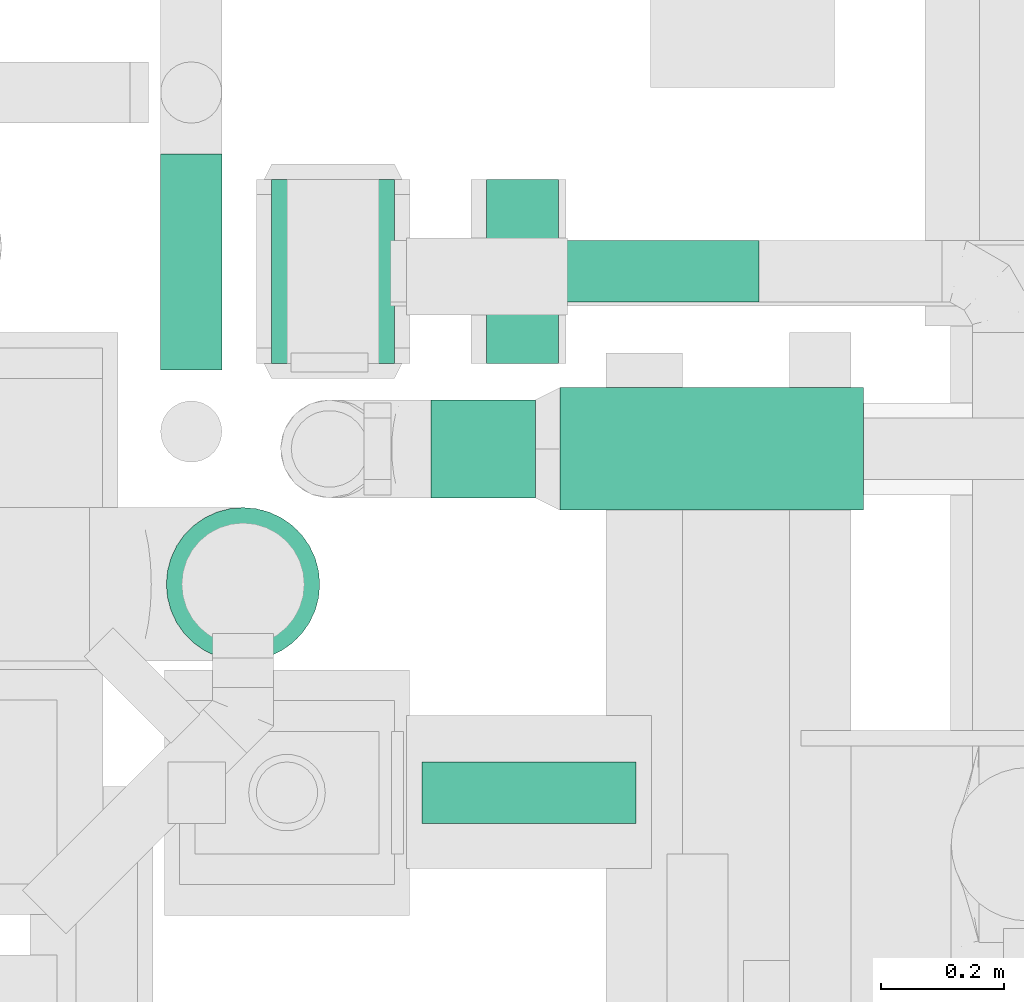
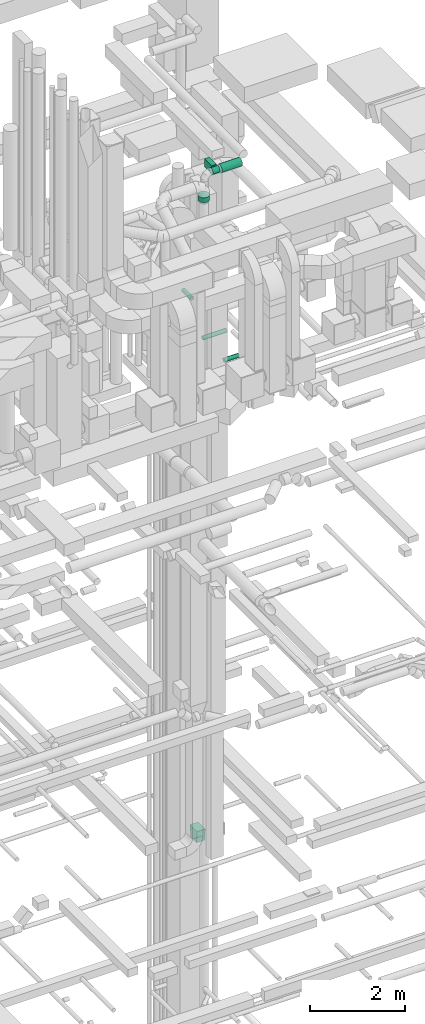
# One storey, part 236 of 337: 7 flow segments, 1 flow fitting.
"""IFC2X3 building model written with IfcOpenShell, lengths in millimetres."""

from ifc_helpers import new_model, entity, si_unit, converted_unit, derived_unit, direction, frame, origin, origin_2d_with_axis, place, context, subcontext, project, spatial, polyline, rectangle, circle, outline, extrude, source, transform, mapped, material, type_object, type_shapes, element, save


model = new_model("IFC2X3")

# Units and contexts
model_context = context("Model", 3, precision=0.01, world=origin(), true_north=direction((6.12303176911189e-17, 1.0)))
body_context = subcontext(model_context, "Body", "Model", "MODEL_VIEW")
ifc_project = project(units=[si_unit("LENGTHUNIT", "METRE", prefix="MILLI"), si_unit("AREAUNIT", "SQUARE_METRE"), si_unit("VOLUMEUNIT", "CUBIC_METRE"), converted_unit("PLANEANGLEUNIT", "DEGREE", entity("IfcRatioMeasure", 0.0174532925199433), si_unit("PLANEANGLEUNIT", "RADIAN"), dimensions=[0, 0, 0, 0, 0, 0, 0]), si_unit("MASSUNIT", "GRAM", prefix="KILO"), derived_unit("MASSDENSITYUNIT", [(si_unit("MASSUNIT", "GRAM", prefix="KILO"), 1), (si_unit("LENGTHUNIT", "METRE"), -3)]), derived_unit("MOMENTOFINERTIAUNIT", [(si_unit("LENGTHUNIT", "METRE"), 4)]), si_unit("TIMEUNIT", "SECOND"), si_unit("FREQUENCYUNIT", "HERTZ"), si_unit("THERMODYNAMICTEMPERATUREUNIT", "DEGREE_CELSIUS"), derived_unit("THERMALTRANSMITTANCEUNIT", [(si_unit("MASSUNIT", "GRAM", prefix="KILO"), 1), (si_unit("THERMODYNAMICTEMPERATUREUNIT", "KELVIN"), -1), (si_unit("TIMEUNIT", "SECOND"), -3)]), derived_unit("VOLUMETRICFLOWRATEUNIT", [(si_unit("LENGTHUNIT", "METRE"), 3), (si_unit("TIMEUNIT", "SECOND"), -1)]), derived_unit("MASSFLOWRATEUNIT", [(si_unit("MASSUNIT", "GRAM", prefix="KILO"), 1), (si_unit("TIMEUNIT", "SECOND"), -1)]), derived_unit("ROTATIONALFREQUENCYUNIT", [(si_unit("TIMEUNIT", "SECOND"), -1)]), si_unit("ELECTRICCURRENTUNIT", "AMPERE"), si_unit("ELECTRICVOLTAGEUNIT", "VOLT"), si_unit("POWERUNIT", "WATT"), si_unit("FORCEUNIT", "NEWTON", prefix="KILO"), si_unit("ILLUMINANCEUNIT", "LUX"), si_unit("LUMINOUSFLUXUNIT", "LUMEN"), si_unit("LUMINOUSINTENSITYUNIT", "CANDELA"), derived_unit("USERDEFINED", [(si_unit("MASSUNIT", "GRAM", prefix="KILO"), -1), (si_unit("LENGTHUNIT", "METRE"), -2), (si_unit("TIMEUNIT", "SECOND"), 3), (si_unit("LUMINOUSFLUXUNIT", "LUMEN"), 1)]), derived_unit("LINEARVELOCITYUNIT", [(si_unit("LENGTHUNIT", "METRE"), 1), (si_unit("TIMEUNIT", "SECOND"), -1)]), si_unit("PRESSUREUNIT", "PASCAL"), derived_unit("USERDEFINED", [(si_unit("LENGTHUNIT", "METRE"), -2), (si_unit("MASSUNIT", "GRAM", prefix="KILO"), 1), (si_unit("TIMEUNIT", "SECOND"), -2)]), derived_unit("LINEARFORCEUNIT", [(si_unit("MASSUNIT", "GRAM", prefix="KILO"), 1), (si_unit("LENGTHUNIT", "METRE"), 1), (si_unit("TIMEUNIT", "SECOND"), -2), (si_unit("LENGTHUNIT", "METRE"), -1)]), derived_unit("PLANARFORCEUNIT", [(si_unit("MASSUNIT", "GRAM", prefix="KILO"), 1), (si_unit("LENGTHUNIT", "METRE"), 1), (si_unit("TIMEUNIT", "SECOND"), -2), (si_unit("LENGTHUNIT", "METRE"), -2)])], contexts=[model_context])

# Site, building, storey
site_placement = place(None, origin())
site = spatial("IfcSite", under=ifc_project, at=site_placement, CompositionType="ELEMENT")
building_placement = place(site_placement, origin())
building = spatial("IfcBuilding", under=site, at=building_placement, CompositionType="ELEMENT")
storey_placement = place(building_placement, origin())
storey = spatial("IfcBuildingStorey", under=building, at=storey_placement, CompositionType="ELEMENT", Elevation=0.0)

# Flow segments
duct_segment_type_1 = type_object("IfcDuctSegmentType", PredefinedType="NOTDEFINED")
flow_segment_1_placement = place(storey_placement, frame((59675.69, 11762.79, 27308.4)))
element("IfcFlowSegment", 1, at=flow_segment_1_placement, inside=storey, type_object=duct_segment_type_1, context=body_context, shape_type="SweptSolid", body=[
    extrude(circle(Radius=50.0, at=origin_2d_with_axis()), frame((0.0, 51.6, 51.6), z_axis=(1.0, 0.0, 0.0), x_axis=(0.0, -1.0, 0.0)), (0.0, 0.0, 1.0), 574.049631088951),
])
flow_segment_2_placement = place(storey_placement, frame((59700.56, 10913.04, 27248.4)))
element("IfcFlowSegment", 2, at=flow_segment_2_placement, inside=storey, type_object=duct_segment_type_1, context=body_context, shape_type="SweptSolid", body=[
    extrude(circle(Radius=50.0, at=origin_2d_with_axis()), frame((0.0, 51.6, 51.6), z_axis=(1.0, 0.0, 0.0), x_axis=(0.0, -1.0, 0.0)), (0.0, 0.0, 1.0), 348.958929779338),
])
flow_segment_3_placement = place(storey_placement, frame((59272.94, 11653.05, 28548.4)))
element("IfcFlowSegment", 3, at=flow_segment_3_placement, inside=storey, type_object=duct_segment_type_1, context=body_context, shape_type="SweptSolid", body=[
    extrude(circle(Radius=50.0, at=origin_2d_with_axis()), frame((51.6, 0.0, 51.6), z_axis=(0.0, 1.0, 0.0), x_axis=(-1.0, 0.0, 0.0)), (0.0, 0.0, 1.0), 352.586750161913),
])
flow_segment_4_placement = place(storey_placement, frame((59925.7, 11423.3, 31698.4)))
element("IfcFlowSegment", 4, at=flow_segment_4_placement, inside=storey, type_object=duct_segment_type_1, context=body_context, shape_type="SweptSolid", body=[
    extrude(circle(Radius=100.0, at=origin_2d_with_axis()), frame((0.0, 101.6, 101.6), z_axis=(1.0, 0.0, 0.0), x_axis=(0.0, -1.0, 0.0)), (0.0, 0.0, 1.0), 494.3347193693),
])
flow_segment_5_placement = place(storey_placement, frame((59715.67, 11443.3, 31718.4)))
element("IfcFlowSegment", 5, at=flow_segment_5_placement, inside=storey, type_object=duct_segment_type_1, context=body_context, shape_type="SweptSolid", body=[
    extrude(circle(Radius=80.0, at=origin_2d_with_axis()), frame((0.0, 81.6, 81.6), z_axis=(1.0, 0.0, 0.0), x_axis=(0.0, -1.0, 0.0)), (0.0, 0.0, 1.0), 170.032076022465),
])
flow_segment_6_placement = place(storey_placement, frame((59282.34, 11177.59, 31319.6)))
element("IfcFlowSegment", 6, at=flow_segment_6_placement, inside=storey, type_object=duct_segment_type_1, context=body_context, shape_type="SweptSolid", body=[
    extrude(circle(Radius=125.0, at=origin_2d_with_axis()), frame((126.6, 126.6, 0.0), z_axis=(0.0, 0.0, 1.0), x_axis=(0.0, -1.0, 0.0)), (0.0, 0.0, 1.0), 130.000000000074),
])
duct_segment_type_2 = type_object("IfcDuctSegmentType", PredefinedType="NOTDEFINED")
flow_segment_7_placement = place(storey_placement, frame((59805.69, 11664.2, 31625.0)))
element("IfcFlowSegment", 7, at=flow_segment_7_placement, inside=storey, type_object=duct_segment_type_2, context=body_context, shape_type="SweptSolid", body=[
    extrude(rectangle(XDim=117.24213999991, YDim=299.999999999999, at=origin_2d_with_axis()), frame((58.62, 150.0, 0.0)), (0.0, 0.0, 1.0), 199.999999999998),
])

# Flow fitting
ifc_material = material()
duct_fitting_type = type_object("IfcDuctFittingType", PredefinedType="NOTDEFINED", material=ifc_material)
shared_shape = source(origin(), body_context, "Body", "SweptSolid", [
    extrude(outline(polyline([(-161.94, -137.03), (139.1, -137.03), (159.86, 112.11), (-137.03, 161.94), (-161.94, -137.03)])), frame((150.0, -100.0, 0.0), z_axis=(0.0, 1.0, 0.0), x_axis=(0.996545758244872, 0.0, -0.0830454798538357)), (0.0, 0.0, 1.0), 200.0),
])
type_shapes(duct_fitting_type, [shared_shape])
flow_fitting_placement = place(storey_placement, frame((59555.69, 11814.2, 14862.21), z_axis=(0.0, -1.0, 0.0), x_axis=(0.0, 0.0, -1.0)))
element("IfcFlowFitting", 8, at=flow_fitting_placement, inside=storey, type_object=duct_fitting_type, material=ifc_material, context=body_context, shape_type="MappedRepresentation", body=[
    mapped(shared_shape, transform((0.0, 0.0, 0.0), scale=1.0)),
])

save(model, "model.ifc")
